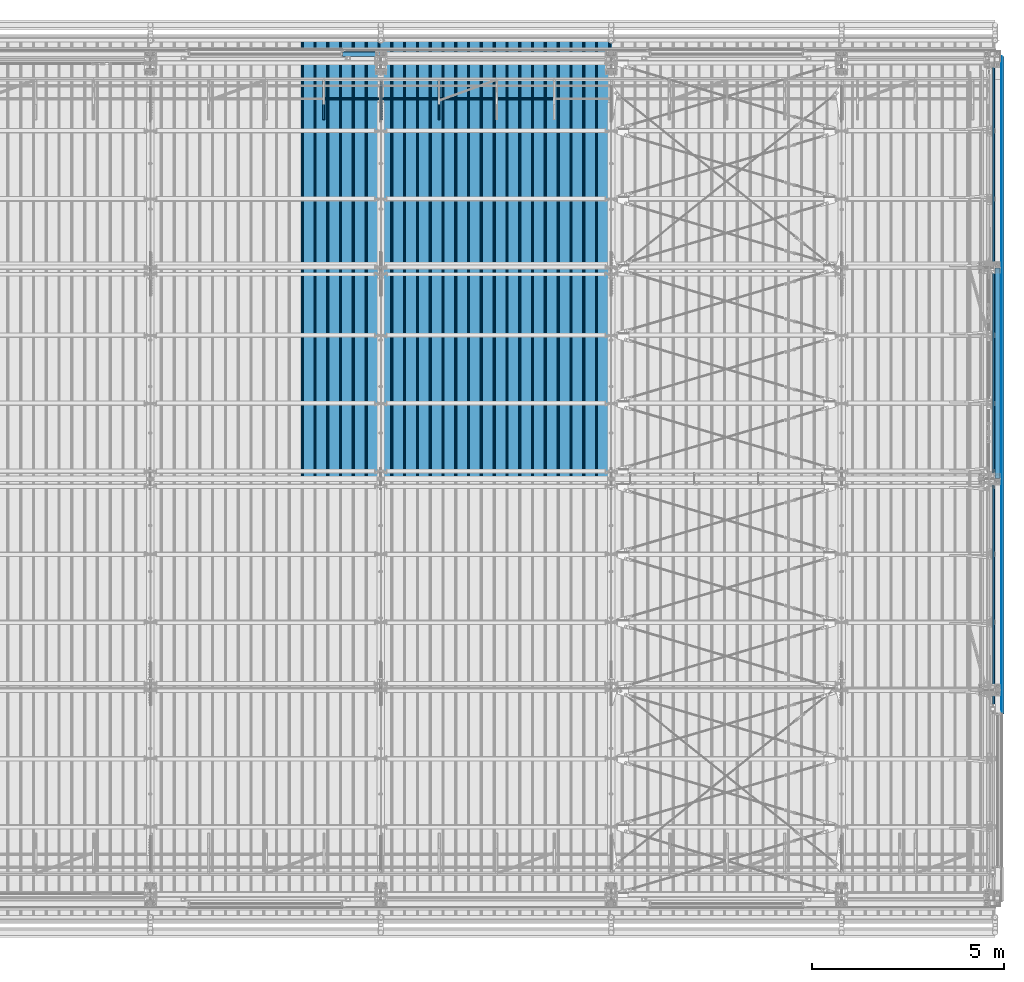
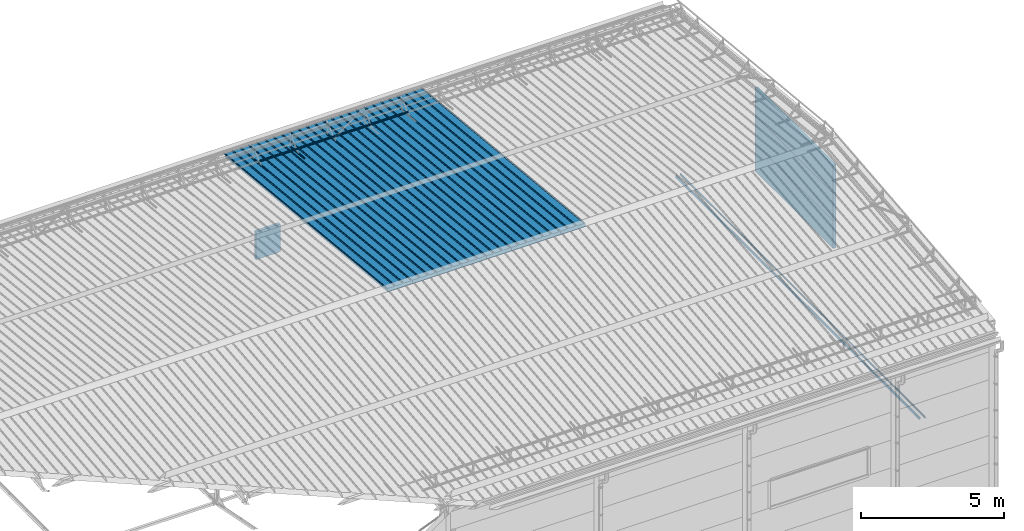
# One storey, part 74 of 709: 19 beams, 19 elements without a shape of their own.
"""IFC4 building model written with IfcOpenShell, lengths in millimetres."""

from ifc_helpers import new_model, si_unit, direction, frame, origin_with_axes, place, context, subcontext, project, spatial, line, indexed_curve, outline, extrude, material, element, aggregate, save


model = new_model("IFC4")

# Units and contexts
model_context = context("Model", 3, precision=0.2, world=origin_with_axes(), true_north=direction((0.0, 1.0)))
body_context = subcontext(model_context, "Body", "Model", "MODEL_VIEW")
ifc_project = project(units=[si_unit("LENGTHUNIT", "METRE", prefix="MILLI"), si_unit("AREAUNIT", "SQUARE_METRE"), si_unit("VOLUMEUNIT", "CUBIC_METRE"), si_unit("MASSUNIT", "GRAM", prefix="KILO"), si_unit("TIMEUNIT", "SECOND"), si_unit("PLANEANGLEUNIT", "RADIAN"), si_unit("SOLIDANGLEUNIT", "STERADIAN"), si_unit("THERMODYNAMICTEMPERATUREUNIT", "DEGREE_CELSIUS"), si_unit("LUMINOUSINTENSITYUNIT", "LUMEN")], contexts=[model_context])

# Site, building, storey
site_placement = place(None, origin_with_axes())
site = spatial("IfcSite", under=ifc_project, at=site_placement, CompositionType="ELEMENT")
building_placement = place(site_placement, origin_with_axes())
building = spatial("IfcBuilding", under=site, at=building_placement, Name="Undefined", CompositionType="ELEMENT")
storey_placement = place(building_placement, origin_with_axes())
storey = spatial("IfcBuildingStorey", under=building, at=storey_placement, Name="Undefined", CompositionType="ELEMENT", Elevation=0.0)

# Assembly, beam
assembly_1_placement = place(storey_placement, frame((39452.44, 11009.10459, 8419.96887), z_axis=(1.0, 0.0, 0.0), x_axis=(0.0, 0.9950371902, -0.099503719)))
assembly_1 = element("IfcElementAssembly", 1, at=assembly_1_placement, inside=storey)
ifc_material_1 = material(Name="Insulation", Category="Insulation")
beam_1_placement = place(assembly_1_placement, origin_with_axes())
beam_1 = element("IfcBeam", 2, at=beam_1_placement, material=ifc_material_1, ObjectType="P-99", context=body_context, shape_type="SolidModel", body=[
    extrude(outline(indexed_curve([(-509.8453, 89.5), (-490.1547, 89.5), (-471.67949, 57.5), (-471.67949, -88.5), (-436.67949, -88.5), (-436.67949, -91.5), (562.55841, -91.5), (562.55841, -89.5), (527.55841, -89.5), (527.55841, 57.5), (510.2379, 88.5), (489.7621, 88.5), (472.44159, 58.5), (196.71923, 58.5), (177.66667, 91.5), (155.66667, 91.5), (136.61411, 58.5), (-136.61411, 58.5), (-155.66667, 91.5), (-177.66667, 91.5), (-196.71923, 58.5), (-469.94744, 58.5), (-489.0, 91.5), (-511.0, 91.5), (-527.16581, 63.5), (-525.43376, 62.5)], segments=[line(1, 2, 3, 4, 5, 6, 7, 8, 9, 10, 11, 12, 13, 14, 15, 16, 17, 18, 19, 20, 21, 22, 23, 24, 25, 26, 1)])), frame((0.0, 0.0, 0.0), z_axis=(-1.0, 0.0, 0.0), x_axis=(0.0, 0.0, 1.0)), (0.0, 0.0, -1.0), 11459.0),
])
aggregate(assembly_1, [beam_1])

assembly_2_placement = place(storey_placement, frame((38452.44, 11009.10459, 8419.96887), z_axis=(1.0, 0.0, 0.0), x_axis=(0.0, 0.9950371902, -0.099503719)))
assembly_2 = element("IfcElementAssembly", 3, at=assembly_2_placement, inside=storey)
beam_2_placement = place(assembly_2_placement, origin_with_axes())
beam_2 = element("IfcBeam", 4, at=beam_2_placement, material=ifc_material_1, ObjectType="P-99", context=body_context, shape_type="SolidModel", body=[
    extrude(outline(indexed_curve([(-509.8453, 89.5), (-490.1547, 89.5), (-471.67949, 57.5), (-471.67949, -88.5), (-436.67949, -88.5), (-436.67949, -91.5), (562.55841, -91.5), (562.55841, -89.5), (527.55841, -89.5), (527.55841, 57.5), (510.2379, 88.5), (489.7621, 88.5), (472.44159, 58.5), (196.71923, 58.5), (177.66667, 91.5), (155.66667, 91.5), (136.61411, 58.5), (-136.61411, 58.5), (-155.66667, 91.5), (-177.66667, 91.5), (-196.71923, 58.5), (-469.94744, 58.5), (-489.0, 91.5), (-511.0, 91.5), (-527.16581, 63.5), (-525.43376, 62.5)], segments=[line(1, 2, 3, 4, 5, 6, 7, 8, 9, 10, 11, 12, 13, 14, 15, 16, 17, 18, 19, 20, 21, 22, 23, 24, 25, 26, 1)])), frame((0.0, 0.0, 0.0), z_axis=(-1.0, 0.0, 0.0), x_axis=(0.0, 0.0, 1.0)), (0.0, 0.0, -1.0), 11459.0),
])
aggregate(assembly_2, [beam_2])

assembly_3_placement = place(storey_placement, frame((37452.44, 11009.10459, 8419.96887), z_axis=(1.0, 0.0, 0.0), x_axis=(0.0, 0.9950371902, -0.099503719)))
assembly_3 = element("IfcElementAssembly", 5, at=assembly_3_placement, inside=storey)
beam_3_placement = place(assembly_3_placement, origin_with_axes())
beam_3 = element("IfcBeam", 6, at=beam_3_placement, material=ifc_material_1, ObjectType="P-99", context=body_context, shape_type="SolidModel", body=[
    extrude(outline(indexed_curve([(-509.8453, 89.5), (-490.1547, 89.5), (-471.67949, 57.5), (-471.67949, -88.5), (-436.67949, -88.5), (-436.67949, -91.5), (562.55841, -91.5), (562.55841, -89.5), (527.55841, -89.5), (527.55841, 57.5), (510.2379, 88.5), (489.7621, 88.5), (472.44159, 58.5), (196.71923, 58.5), (177.66667, 91.5), (155.66667, 91.5), (136.61411, 58.5), (-136.61411, 58.5), (-155.66667, 91.5), (-177.66667, 91.5), (-196.71923, 58.5), (-469.94744, 58.5), (-489.0, 91.5), (-511.0, 91.5), (-527.16581, 63.5), (-525.43376, 62.5)], segments=[line(1, 2, 3, 4, 5, 6, 7, 8, 9, 10, 11, 12, 13, 14, 15, 16, 17, 18, 19, 20, 21, 22, 23, 24, 25, 26, 1)])), frame((0.0, 0.0, 0.0), z_axis=(-1.0, 0.0, 0.0), x_axis=(0.0, 0.0, 1.0)), (0.0, 0.0, -1.0), 11459.0),
])
aggregate(assembly_3, [beam_3])

assembly_4_placement = place(storey_placement, frame((36452.44, 11009.10459, 8419.96887), z_axis=(1.0, 0.0, 0.0), x_axis=(0.0, 0.9950371902, -0.099503719)))
assembly_4 = element("IfcElementAssembly", 7, at=assembly_4_placement, inside=storey)
beam_4_placement = place(assembly_4_placement, origin_with_axes())
beam_4 = element("IfcBeam", 8, at=beam_4_placement, material=ifc_material_1, ObjectType="P-99", context=body_context, shape_type="SolidModel", body=[
    extrude(outline(indexed_curve([(-509.8453, 89.5), (-490.1547, 89.5), (-471.67949, 57.5), (-471.67949, -88.5), (-436.67949, -88.5), (-436.67949, -91.5), (562.55841, -91.5), (562.55841, -89.5), (527.55841, -89.5), (527.55841, 57.5), (510.2379, 88.5), (489.7621, 88.5), (472.44159, 58.5), (196.71923, 58.5), (177.66667, 91.5), (155.66667, 91.5), (136.61411, 58.5), (-136.61411, 58.5), (-155.66667, 91.5), (-177.66667, 91.5), (-196.71923, 58.5), (-469.94744, 58.5), (-489.0, 91.5), (-511.0, 91.5), (-527.16581, 63.5), (-525.43376, 62.5)], segments=[line(1, 2, 3, 4, 5, 6, 7, 8, 9, 10, 11, 12, 13, 14, 15, 16, 17, 18, 19, 20, 21, 22, 23, 24, 25, 26, 1)])), frame((0.0, 0.0, 0.0), z_axis=(-1.0, 0.0, 0.0), x_axis=(0.0, 0.0, 1.0)), (0.0, 0.0, -1.0), 11459.0),
])
aggregate(assembly_4, [beam_4])

assembly_5_placement = place(storey_placement, frame((35452.44, 11009.10459, 8419.96887), z_axis=(1.0, 0.0, 0.0), x_axis=(0.0, 0.9950371902, -0.099503719)))
assembly_5 = element("IfcElementAssembly", 9, at=assembly_5_placement, inside=storey)
beam_5_placement = place(assembly_5_placement, origin_with_axes())
beam_5 = element("IfcBeam", 10, at=beam_5_placement, material=ifc_material_1, ObjectType="P-99", context=body_context, shape_type="SolidModel", body=[
    extrude(outline(indexed_curve([(-509.8453, 89.5), (-490.1547, 89.5), (-471.67949, 57.5), (-471.67949, -88.5), (-436.67949, -88.5), (-436.67949, -91.5), (562.55841, -91.5), (562.55841, -89.5), (527.55841, -89.5), (527.55841, 57.5), (510.2379, 88.5), (489.7621, 88.5), (472.44159, 58.5), (196.71923, 58.5), (177.66667, 91.5), (155.66667, 91.5), (136.61411, 58.5), (-136.61411, 58.5), (-155.66667, 91.5), (-177.66667, 91.5), (-196.71923, 58.5), (-469.94744, 58.5), (-489.0, 91.5), (-511.0, 91.5), (-527.16581, 63.5), (-525.43376, 62.5)], segments=[line(1, 2, 3, 4, 5, 6, 7, 8, 9, 10, 11, 12, 13, 14, 15, 16, 17, 18, 19, 20, 21, 22, 23, 24, 25, 26, 1)])), frame((0.0, 0.0, 0.0), z_axis=(-1.0, 0.0, 0.0), x_axis=(0.0, 0.0, 1.0)), (0.0, 0.0, -1.0), 11459.0),
])
aggregate(assembly_5, [beam_5])

assembly_6_placement = place(storey_placement, frame((34452.44, 11009.10459, 8419.96887), z_axis=(1.0, 0.0, 0.0), x_axis=(0.0, 0.9950371902, -0.099503719)))
assembly_6 = element("IfcElementAssembly", 11, at=assembly_6_placement, inside=storey)
beam_6_placement = place(assembly_6_placement, origin_with_axes())
beam_6 = element("IfcBeam", 12, at=beam_6_placement, material=ifc_material_1, ObjectType="P-99", context=body_context, shape_type="SolidModel", body=[
    extrude(outline(indexed_curve([(-509.8453, 89.5), (-490.1547, 89.5), (-471.67949, 57.5), (-471.67949, -88.5), (-436.67949, -88.5), (-436.67949, -91.5), (562.55841, -91.5), (562.55841, -89.5), (527.55841, -89.5), (527.55841, 57.5), (510.2379, 88.5), (489.7621, 88.5), (472.44159, 58.5), (196.71923, 58.5), (177.66667, 91.5), (155.66667, 91.5), (136.61411, 58.5), (-136.61411, 58.5), (-155.66667, 91.5), (-177.66667, 91.5), (-196.71923, 58.5), (-469.94744, 58.5), (-489.0, 91.5), (-511.0, 91.5), (-527.16581, 63.5), (-525.43376, 62.5)], segments=[line(1, 2, 3, 4, 5, 6, 7, 8, 9, 10, 11, 12, 13, 14, 15, 16, 17, 18, 19, 20, 21, 22, 23, 24, 25, 26, 1)])), frame((0.0, 0.0, 0.0), z_axis=(-1.0, 0.0, 0.0), x_axis=(0.0, 0.0, 1.0)), (0.0, 0.0, -1.0), 11459.0),
])
aggregate(assembly_6, [beam_6])

assembly_7_placement = place(storey_placement, frame((33452.44, 11009.10459, 8419.96887), z_axis=(1.0, 0.0, 0.0), x_axis=(0.0, 0.9950371902, -0.099503719)))
assembly_7 = element("IfcElementAssembly", 13, at=assembly_7_placement, inside=storey)
beam_7_placement = place(assembly_7_placement, origin_with_axes())
beam_7 = element("IfcBeam", 14, at=beam_7_placement, material=ifc_material_1, ObjectType="P-99", context=body_context, shape_type="SolidModel", body=[
    extrude(outline(indexed_curve([(-509.8453, 89.5), (-490.1547, 89.5), (-471.67949, 57.5), (-471.67949, -88.5), (-436.67949, -88.5), (-436.67949, -91.5), (562.55841, -91.5), (562.55841, -89.5), (527.55841, -89.5), (527.55841, 57.5), (510.2379, 88.5), (489.7621, 88.5), (472.44159, 58.5), (196.71923, 58.5), (177.66667, 91.5), (155.66667, 91.5), (136.61411, 58.5), (-136.61411, 58.5), (-155.66667, 91.5), (-177.66667, 91.5), (-196.71923, 58.5), (-469.94744, 58.5), (-489.0, 91.5), (-511.0, 91.5), (-527.16581, 63.5), (-525.43376, 62.5)], segments=[line(1, 2, 3, 4, 5, 6, 7, 8, 9, 10, 11, 12, 13, 14, 15, 16, 17, 18, 19, 20, 21, 22, 23, 24, 25, 26, 1)])), frame((0.0, 0.0, 0.0), z_axis=(-1.0, 0.0, 0.0), x_axis=(0.0, 0.0, 1.0)), (0.0, 0.0, -1.0), 11459.0),
])
aggregate(assembly_7, [beam_7])

assembly_8_placement = place(storey_placement, frame((32452.44, 11009.10459, 8419.96887), z_axis=(1.0, 0.0, 0.0), x_axis=(0.0, 0.9950371902, -0.099503719)))
assembly_8 = element("IfcElementAssembly", 15, at=assembly_8_placement, inside=storey)
beam_8_placement = place(assembly_8_placement, origin_with_axes())
beam_8 = element("IfcBeam", 16, at=beam_8_placement, material=ifc_material_1, ObjectType="P-99", context=body_context, shape_type="SolidModel", body=[
    extrude(outline(indexed_curve([(-509.8453, 89.5), (-490.1547, 89.5), (-471.67949, 57.5), (-471.67949, -88.5), (-436.67949, -88.5), (-436.67949, -91.5), (562.55841, -91.5), (562.55841, -89.5), (527.55841, -89.5), (527.55841, 57.5), (510.2379, 88.5), (489.7621, 88.5), (472.44159, 58.5), (196.71923, 58.5), (177.66667, 91.5), (155.66667, 91.5), (136.61411, 58.5), (-136.61411, 58.5), (-155.66667, 91.5), (-177.66667, 91.5), (-196.71923, 58.5), (-469.94744, 58.5), (-489.0, 91.5), (-511.0, 91.5), (-527.16581, 63.5), (-525.43376, 62.5)], segments=[line(1, 2, 3, 4, 5, 6, 7, 8, 9, 10, 11, 12, 13, 14, 15, 16, 17, 18, 19, 20, 21, 22, 23, 24, 25, 26, 1)])), frame((0.0, 0.0, 0.0), z_axis=(-1.0, 0.0, 0.0), x_axis=(0.0, 0.0, 1.0)), (0.0, 0.0, -1.0), 11459.0),
])
aggregate(assembly_8, [beam_8])

assembly_9_placement = place(storey_placement, frame((35515.0, 21349.29926, 7565.33969), z_axis=(0.0, 0.099503719, 0.9950371902), x_axis=(0.0, -0.9950371902, 0.099503719)))
assembly_9 = element("IfcElementAssembly", 17, at=assembly_9_placement, inside=storey)
ifc_material_2 = material(Name="Steel_Undefined", Category="STEEL")
beam_9_placement = place(assembly_9_placement, origin_with_axes())
beam_9 = element("IfcBeam", 18, at=beam_9_placement, material=ifc_material_2, ObjectType="601", context=body_context, shape_type="SolidModel", body=[
    extrude(outline(indexed_curve([(-20.0, -25.0), (20.0, -25.0), (20.0, -22.5), (-17.5, -22.5), (-17.5, 22.5), (20.0, 22.5), (20.0, 25.0), (-20.0, 25.0)], segments=[line(1, 2, 3, 4, 5, 6, 7, 8, 1)])), frame((0.0, 0.0, 0.0), z_axis=(-1.0, 0.0, 0.0), x_axis=(0.0, 0.0, 1.0)), (0.0, 0.0, -1.0), 1000.0),
])
aggregate(assembly_9, [beam_9])

assembly_10_placement = place(storey_placement, frame((34015.0, 21349.29926, 7565.33969), z_axis=(0.0, 0.099503719, 0.9950371902), x_axis=(0.0, -0.9950371902, 0.099503719)))
assembly_10 = element("IfcElementAssembly", 19, at=assembly_10_placement, inside=storey)
beam_10_placement = place(assembly_10_placement, origin_with_axes())
beam_10 = element("IfcBeam", 20, at=beam_10_placement, material=ifc_material_2, ObjectType="601", context=body_context, shape_type="SolidModel", body=[
    extrude(outline(indexed_curve([(-20.0, -25.0), (20.0, -25.0), (20.0, -22.5), (-17.5, -22.5), (-17.5, 22.5), (20.0, 22.5), (20.0, 25.0), (-20.0, 25.0)], segments=[line(1, 2, 3, 4, 5, 6, 7, 8, 1)])), frame((0.0, 0.0, 0.0), z_axis=(-1.0, 0.0, 0.0), x_axis=(0.0, 0.0, 1.0)), (0.0, 0.0, -1.0), 1000.0),
])
aggregate(assembly_10, [beam_10])

assembly_11_placement = place(storey_placement, frame((38515.0, 20892.41357, 7747.26788), z_axis=(0.0, -0.6332377902, 0.7739572992), x_axis=(-1.0, 0.0, 0.0)))
assembly_11 = element("IfcElementAssembly", 21, at=assembly_11_placement, inside=storey)
beam_11_placement = place(assembly_11_placement, origin_with_axes())
beam_11 = element("IfcBeam", 22, at=beam_11_placement, material=ifc_material_2, ObjectType="606", context=body_context, shape_type="SolidModel", body=[
    extrude(outline(indexed_curve([(-20.0, -25.0), (20.0, -25.0), (20.0, -22.5), (-17.5, -22.5), (-17.5, 22.5), (20.0, 22.5), (20.0, 25.0), (-20.0, 25.0)], segments=[line(1, 2, 3, 4, 5, 6, 7, 8, 1)])), frame((0.0, 0.0, 0.0), z_axis=(-1.0, 0.0, 0.0), x_axis=(0.0, 0.0, 1.0)), (0.0, 0.0, -1.0), 6000.0),
])
aggregate(assembly_11, [beam_11])

assembly_12_placement = place(storey_placement, frame((32515.0, 21349.29926, 7565.33969), z_axis=(0.0, 0.099503719, 0.9950371902), x_axis=(0.0, -0.9950371902, 0.099503719)))
assembly_12 = element("IfcElementAssembly", 23, at=assembly_12_placement, inside=storey)
beam_12_placement = place(assembly_12_placement, origin_with_axes())
beam_12 = element("IfcBeam", 24, at=beam_12_placement, material=ifc_material_2, ObjectType="601", context=body_context, shape_type="SolidModel", body=[
    extrude(outline(indexed_curve([(-20.0, -25.0), (20.0, -25.0), (20.0, -22.5), (-17.5, -22.5), (-17.5, 22.5), (20.0, 22.5), (20.0, 25.0), (-20.0, 25.0)], segments=[line(1, 2, 3, 4, 5, 6, 7, 8, 1)])), frame((0.0, 0.0, 0.0), z_axis=(-1.0, 0.0, 0.0), x_axis=(0.0, 0.0, 1.0)), (0.0, 0.0, -1.0), 1000.0),
])
aggregate(assembly_12, [beam_12])

assembly_13_placement = place(storey_placement, frame((33000.0, 22060.0, 3275.0), z_axis=(0.0, 0.0, -1.0), x_axis=(1.0, 0.0, 0.0)))
assembly_13 = element("IfcElementAssembly", 25, at=assembly_13_placement, inside=storey)
beam_13_placement = place(assembly_13_placement, origin_with_axes())
beam_13 = element("IfcBeam", 26, at=beam_13_placement, material=ifc_material_1, ObjectType="P-110", context=body_context, shape_type="SolidModel", body=[
    extrude(outline(indexed_curve([(-595.0, -60.0), (595.0, -60.0), (595.0, 60.0), (-595.0, 60.0)], segments=[line(1, 2, 3, 4, 1)])), frame((0.0, 0.0, 0.0), z_axis=(-1.0, 0.0, 0.0), x_axis=(0.0, 0.0, 1.0)), (0.0, 0.0, -1.0), 990.0),
])
aggregate(assembly_13, [beam_13])

assembly_14_placement = place(storey_placement, frame((50060.0, 11010.0, 4465.0), z_axis=(0.0, 0.0, -1.0), x_axis=(0.0, 1.0, 0.0)))
assembly_14 = element("IfcElementAssembly", 27, at=assembly_14_placement, inside=storey)
beam_14_placement = place(assembly_14_placement, origin_with_axes())
beam_14 = element("IfcBeam", 28, at=beam_14_placement, material=ifc_material_1, ObjectType="P-135", context=body_context, shape_type="SolidModel", body=[
    extrude(outline(indexed_curve([(-595.0, -60.0), (595.0, -60.0), (595.0, 60.0), (-595.0, 60.0)], segments=[line(1, 2, 3, 4, 1)])), frame((0.0, 0.0, 0.0), z_axis=(-1.0, 0.0, 0.0), x_axis=(0.0, 0.0, 1.0)), (0.0, 0.0, -1.0), 5480.0),
])
aggregate(assembly_14, [beam_14])

assembly_15_placement = place(storey_placement, frame((50060.0, 11010.0, 5655.0), z_axis=(0.0, 0.0, -1.0), x_axis=(0.0, 1.0, 0.0)))
assembly_15 = element("IfcElementAssembly", 29, at=assembly_15_placement, inside=storey)
beam_15_placement = place(assembly_15_placement, origin_with_axes())
beam_15 = element("IfcBeam", 30, at=beam_15_placement, material=ifc_material_1, ObjectType="P-135", context=body_context, shape_type="SolidModel", body=[
    extrude(outline(indexed_curve([(-595.0, -60.0), (595.0, -60.0), (595.0, 60.0), (-595.0, 60.0)], segments=[line(1, 2, 3, 4, 1)])), frame((0.0, 0.0, 0.0), z_axis=(-1.0, 0.0, 0.0), x_axis=(0.0, 0.0, 1.0)), (0.0, 0.0, -1.0), 5480.0),
])
aggregate(assembly_15, [beam_15])

assembly_16_placement = place(storey_placement, frame((50060.0, 11010.0, 6845.0), z_axis=(0.0, 0.0, -1.0), x_axis=(0.0, 1.0, 0.0)))
assembly_16 = element("IfcElementAssembly", 31, at=assembly_16_placement, inside=storey)
beam_16_placement = place(assembly_16_placement, origin_with_axes())
beam_16 = element("IfcBeam", 32, at=beam_16_placement, material=ifc_material_1, ObjectType="P-135", context=body_context, shape_type="SolidModel", body=[
    extrude(outline(indexed_curve([(-595.0, -60.0), (595.0, -60.0), (595.0, 60.0), (-595.0, 60.0)], segments=[line(1, 2, 3, 4, 1)])), frame((0.0, 0.0, 0.0), z_axis=(-1.0, 0.0, 0.0), x_axis=(0.0, 0.0, 1.0)), (0.0, 0.0, -1.0), 5480.0),
])
aggregate(assembly_16, [beam_16])

assembly_17_placement = place(storey_placement, frame((50170.375, 22000.0, 370.0), z_axis=(-1.0, 0.0, 0.0), x_axis=(0.0, -1.0, 0.0)))
assembly_17 = element("IfcElementAssembly", 33, at=assembly_17_placement, inside=storey)
beam_17_placement = place(assembly_17_placement, origin_with_axes())
beam_17 = element("IfcBeam", 34, at=beam_17_placement, material=ifc_material_2, context=body_context, shape_type="SolidModel", body=[
    extrude(outline(indexed_curve([(0.375, -20.0), (0.375, 19.25), (0.495, 19.25), (0.495, 5.0), (1.245, 5.0), (1.245, 20.0), (-0.375, 20.0), (-0.375, -19.68934), (-59.625, -78.93934), (-59.625, -118.93934), (-52.125, -105.94896), (-52.77452, -105.57396), (-58.875, -116.1403), (-58.875, -79.25)], segments=[line(1, 2, 3, 4, 5, 6, 7, 8, 9, 10, 11, 12, 13, 14, 1)])), frame((0.0, 0.0, 0.0), z_axis=(-1.0, 0.0, 0.0), x_axis=(0.0, 0.0, 1.0)), (0.0, 0.0, -1.0), 17120.0),
])
aggregate(assembly_17, [beam_17])

assembly_18_placement = place(storey_placement, frame((50155.0, 4880.0, 350.0), z_axis=(0.0, 0.0, -1.0), x_axis=(0.0, 1.0, 0.0)))
assembly_18 = element("IfcElementAssembly", 35, at=assembly_18_placement, inside=storey)
beam_18_placement = place(assembly_18_placement, origin_with_axes())
beam_18 = element("IfcBeam", 36, at=beam_18_placement, material=ifc_material_2, context=body_context, shape_type="SolidModel", body=[
    extrude(outline(indexed_curve([(-35.0, -1.0), (35.0, -1.0), (60.98076, 14.0), (59.98076, 15.73205), (34.4641, 1.0), (-35.0, 1.0)], segments=[line(1, 2, 3, 4, 5, 6, 1)])), frame((0.0, 0.0, 0.0), z_axis=(-1.0, 0.0, 0.0), x_axis=(0.0, 0.0, 1.0)), (0.0, 0.0, -1.0), 17120.0),
])
aggregate(assembly_18, [beam_18])

assembly_19_placement = place(storey_placement, frame((49985.0, 22000.0, 350.0), z_axis=(0.0, 0.0, -1.0), x_axis=(0.0, -1.0, 0.0)))
assembly_19 = element("IfcElementAssembly", 37, at=assembly_19_placement, inside=storey)
beam_19_placement = place(assembly_19_placement, origin_with_axes())
beam_19 = element("IfcBeam", 38, at=beam_19_placement, material=ifc_material_2, context=body_context, shape_type="SolidModel", body=[
    extrude(outline(indexed_curve([(-45.0, -1.0), (45.0, -1.0), (45.0, 49.0), (43.0, 49.0), (43.0, 1.0), (-45.0, 1.0)], segments=[line(1, 2, 3, 4, 5, 6, 1)])), frame((0.0, 0.0, 0.0), z_axis=(-1.0, 0.0, 0.0), x_axis=(0.0, 0.0, 1.0)), (0.0, 0.0, -1.0), 17120.0),
])
aggregate(assembly_19, [beam_19])

save(model, "model.ifc")
